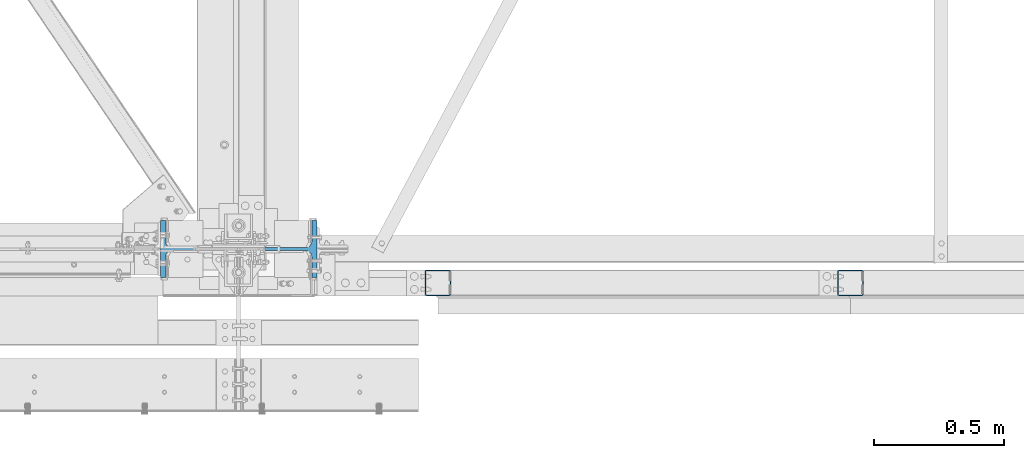
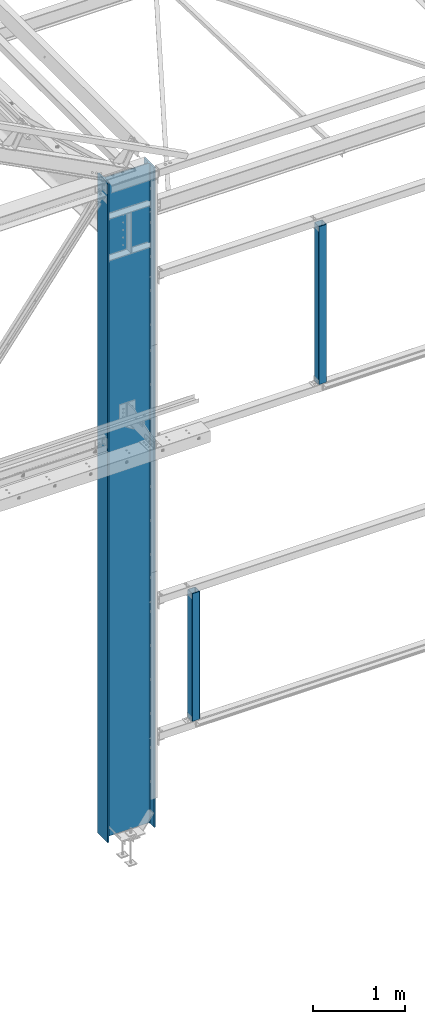
# One storey, part 10 of 496: 3 columns, 3 elements without a shape of their own.
"""IFC2X3 building model written with IfcOpenShell, lengths in millimetres."""

from ifc_helpers import new_model, si_unit, frame, origin_with_axes, origin_2d_with_axis, place, context, subcontext, project, spatial, hollow_rectangle, i_section, extrude, material, type_object, element, aggregate, save


model = new_model("IFC2X3")

# Units and contexts
model_context = context("Model", 3, precision=1e-05, world=origin_with_axes())
body_context = subcontext(model_context, "Body", "Model", "MODEL_VIEW")
ifc_project = project(units=[si_unit("LENGTHUNIT", "METRE", prefix="MILLI"), si_unit("AREAUNIT", "SQUARE_METRE"), si_unit("VOLUMEUNIT", "CUBIC_METRE"), si_unit("MASSUNIT", "GRAM", prefix="KILO"), si_unit("TIMEUNIT", "SECOND"), si_unit("PLANEANGLEUNIT", "RADIAN"), si_unit("SOLIDANGLEUNIT", "STERADIAN"), si_unit("THERMODYNAMICTEMPERATUREUNIT", "DEGREE_CELSIUS"), si_unit("LUMINOUSINTENSITYUNIT", "LUMEN")], contexts=[model_context])

# Site, building, storey
site_placement = place(None, origin_with_axes())
site = spatial("IfcSite", under=ifc_project, at=site_placement, CompositionType="ELEMENT")
building_placement = place(site_placement, origin_with_axes())
building = spatial("IfcBuilding", under=site, at=building_placement, Name="Undefined", CompositionType="ELEMENT")
storey_placement = place(building_placement, origin_with_axes())
storey = spatial("IfcBuildingStorey", under=building, at=storey_placement, Name="Undefined", CompositionType="ELEMENT", Elevation=0.0)

# Assembly, column
assembly_1_placement = place(storey_placement, origin_with_axes())
assembly_1 = element("IfcElementAssembly", 1, at=assembly_1_placement, inside=storey, Name="MONTANT", AssemblyPlace="NOTDEFINED", PredefinedType="NOTDEFINED")
ifc_material_1 = material(Name="Undefined/S235-E24")
column_type_1 = type_object("IfcColumnType", PredefinedType="NOTDEFINED")
column_1_placement = place(assembly_1_placement, frame((31230.000000019, -129.999768794552, 5004.99999999975), z_axis=(0.0, 0.0, 1.0), x_axis=(0.0, 1.0, 0.0)))
column_1 = element("IfcColumn", 2, at=column_1_placement, type_object=column_type_1, material=ifc_material_1, Name="MONTANT", context=body_context, shape_type="SweptSolid", body=[
    extrude(hollow_rectangle(XDim=100.0, YDim=100.0, WallThickness=4.0, InnerFilletRadius=4.0, OuterFilletRadius=8.0, at=origin_2d_with_axis()), frame((0.0, 0.0, 2090.0), z_axis=(0.0, 0.0, -1.0), x_axis=(0.0, 1.0, 0.0)), (0.0, 0.0, 1.0), 2090.0),
])
aggregate(assembly_1, [column_1])

assembly_2_placement = place(storey_placement, origin_with_axes())
assembly_2 = element("IfcElementAssembly", 3, at=assembly_2_placement, inside=storey, Name="MONTANT", AssemblyPlace="NOTDEFINED", PredefinedType="NOTDEFINED")
column_2_placement = place(assembly_2_placement, frame((29645.000000019, -129.999780565376, 1104.9999999997), z_axis=(0.0, 0.0, 1.0), x_axis=(0.0, 1.0, 0.0)))
column_2 = element("IfcColumn", 4, at=column_2_placement, type_object=column_type_1, material=ifc_material_1, Name="MONTANT", context=body_context, shape_type="SweptSolid", body=[
    extrude(hollow_rectangle(XDim=100.0, YDim=100.0, WallThickness=4.0, InnerFilletRadius=4.0, OuterFilletRadius=8.0, at=origin_2d_with_axis()), frame((0.0, 0.0, 1690.0), z_axis=(0.0, 0.0, -1.0), x_axis=(0.0, 1.0, 0.0)), (0.0, 0.0, 1.0), 1690.0),
])
aggregate(assembly_2, [column_2])

assembly_3_placement = place(storey_placement, origin_with_axes())
assembly_3 = element("IfcElementAssembly", 5, at=assembly_3_placement, inside=storey, Name="POTEAU", AssemblyPlace="NOTDEFINED", PredefinedType="NOTDEFINED")
ifc_material_2 = material(Name="Undefined/S275-E28")
column_type_2 = type_object("IfcColumnType", Name="IPE600", PredefinedType="NOTDEFINED")
column_3_placement = place(assembly_3_placement, frame((28879.9971504447, 0.0, -185.0), z_axis=(0.0, 0.0, 1.0), x_axis=(-1.0, 0.0, 0.0)))
column_3 = element("IfcColumn", 6, at=column_3_placement, type_object=column_type_2, material=ifc_material_2, Name="POTEAU", ObjectType="IPE600", context=body_context, shape_type="SweptSolid", body=[
    extrude(i_section(OverallWidth=220.0, OverallDepth=600.0, WebThickness=12.0, FlangeThickness=19.0, FilletRadius=24.0, at=origin_2d_with_axis()), frame((-4.61897654049632e-19, 0.0, 8725.0000000004), z_axis=(0.0, 0.0, -1.0), x_axis=(0.0, 1.0, 0.0)), (0.0, 0.0, 1.0), 8725.0),
])
aggregate(assembly_3, [column_3])

save(model, "model.ifc")
